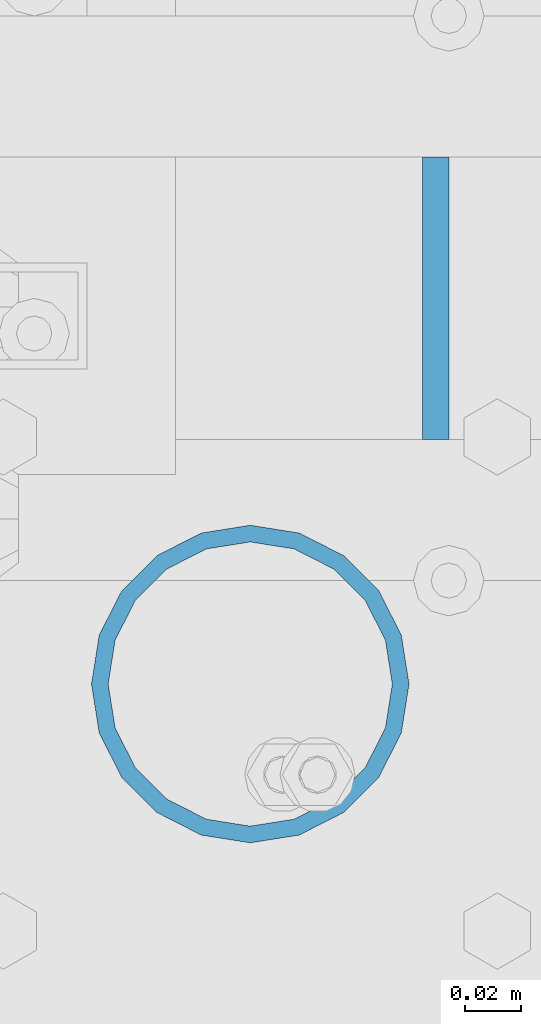
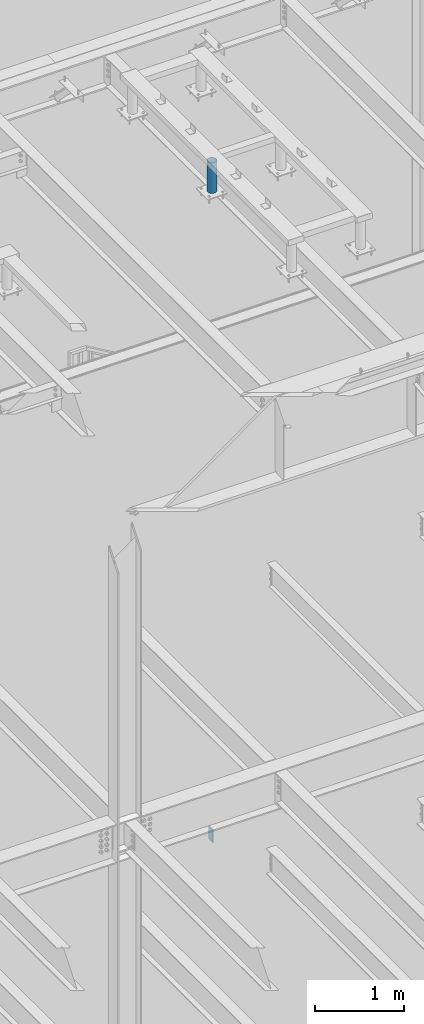
# One storey, part 563 of 1179: 2 columns, 2 elements without a shape of their own.
"""IFC2X3 building model written with IfcOpenShell, lengths in millimetres."""

import ifcopenshell
import ifcopenshell.guid

model = None  # the IFC model being written
_history = None  # IfcOwnerHistory: only IFC2X3 demands one
_inside = {}  # id of a spatial element -> (the spatial element, [elements in it])
_under = {}  # id of a project, library or spatial element -> (it, [spatial elements below it])
_declared = {}  # id of a project -> (the project, [libraries it declares])
_typed = {}  # id of a type object -> (the type object, [elements of that type])
_made_of = {}  # id of a material, layer set ... -> (it, [elements and type objects made of it])


def new_model(schema):
    """Start an empty IFC model of exactly this schema.

    Asked for "IFC4X3", IfcOpenShell would pick the latest addendum, in which some entities
    have other attributes; the version numbers below select the first issue.
    IFC2X3 requires an IfcOwnerHistory on every rooted entity: one is made here for all.
    """
    global model, _history
    if schema == "IFC4X3":
        model = ifcopenshell.file(schema_version=(4, 3, 0, 0))
    else:
        model = ifcopenshell.file(schema=schema)
    _inside.clear()
    _under.clear()
    _declared.clear()
    _typed.clear()
    _made_of.clear()
    _history = None
    if model.schema == "IFC2X3":
        org = make("IfcOrganization", Name="unknown")
        user = make(
            "IfcPersonAndOrganization",
            ThePerson=make("IfcPerson", FamilyName="unknown"),
            TheOrganization=org,
        )
        app = make(
            "IfcApplication",
            ApplicationDeveloper=org,
            Version="unknown",
            ApplicationFullName="unknown",
            ApplicationIdentifier="unknown",
        )
        _history = make(
            "IfcOwnerHistory",
            OwningUser=user,
            OwningApplication=app,
            ChangeAction="ADDED",
            CreationDate=0,
        )
    return model


def make(cls, **values):
    """One entity of the class cls with the attributes given. An attribute that is None is left unset."""
    return model.create_entity(
        cls, **{name: value for name, value in values.items() if value is not None}
    )


def rooted(cls, **values):
    """An entity with a GlobalId (a new one), such as an element, a storey or a relation."""
    return make(cls, GlobalId=ifcopenshell.guid.new(), OwnerHistory=_history, **values)


def si_unit(unit_type, name, prefix=None):
    """IfcSIUnit, for example si_unit("LENGTHUNIT", "METRE", prefix="MILLI")."""
    return make("IfcSIUnit", UnitType=unit_type, Prefix=prefix, Name=name)


def assignment(units):
    """IfcUnitAssignment: the units of a project."""
    return None if units is None else make("IfcUnitAssignment", Units=units)


def point(xyz):
    """IfcCartesianPoint."""
    return None if xyz is None else make("IfcCartesianPoint", Coordinates=xyz)


def direction(xyz):
    """IfcDirection."""
    return None if xyz is None else make("IfcDirection", DirectionRatios=xyz)


def frame(location, z_axis=None, x_axis=None):
    """IfcAxis2Placement3D, a coordinate frame: its origin and axes. An axis left out is left unset."""
    return make(
        "IfcAxis2Placement3D",
        Location=point(location),
        Axis=direction(z_axis),
        RefDirection=direction(x_axis),
    )


def origin_with_axes():
    """The frame at (0, 0, 0) with the z axis (0, 0, 1) and the x axis (1, 0, 0) written out."""
    return frame((0.0, 0.0, 0.0), z_axis=(0.0, 0.0, 1.0), x_axis=(1.0, 0.0, 0.0))


def place(relative_to, where):
    """IfcLocalPlacement: puts the frame where relative to a parent placement (None: the world)."""
    return make(
        "IfcLocalPlacement", PlacementRelTo=relative_to, RelativePlacement=where
    )


def context(
    kind, dimensions, precision=None, world=None, true_north=None, identifier=None
):
    """IfcGeometricRepresentationContext, for example the 3D "Model" context."""
    return make(
        "IfcGeometricRepresentationContext",
        ContextIdentifier=identifier,
        ContextType=kind,
        CoordinateSpaceDimension=dimensions,
        Precision=precision,
        WorldCoordinateSystem=world,
        TrueNorth=true_north,
    )


def subcontext(parent, identifier, kind, view, scale=None):
    """IfcGeometricRepresentationSubContext, for example "Body" below "Model"."""
    return make(
        "IfcGeometricRepresentationSubContext",
        ContextIdentifier=identifier,
        ContextType=kind,
        ParentContext=parent,
        TargetScale=scale,
        TargetView=view,
    )


def project(units=None, contexts=None):
    """IfcProject with its units and contexts."""
    return rooted(
        "IfcProject",
        Name="project",
        RepresentationContexts=contexts,
        UnitsInContext=assignment(units),
    )


def spatial(cls, under=None, at=None, **own):
    """A site, building, storey or space (cls), placed at a placement, below another one or the project."""
    s = rooted(cls, ObjectPlacement=at, **own)
    if under is not None:
        _under.setdefault(under.id(), (under, []))[1].append(s)
    return s


def faces_of(points, faces, orient=None, outer=None):
    """IfcFace entities. A face is a list of loops; a loop is a list of indices into points, from 0.

    orient and outer hold one flag for each loop. By default every Orientation is true, the
    first loop of a face is its IfcFaceOuterBound and the others are IfcFaceBound.
    """
    made = []
    for i, loops in enumerate(faces):
        bounds = []
        for j, loop in enumerate(loops):
            is_outer = j == 0 if outer is None else outer[i][j]
            bounds.append(
                make(
                    "IfcFaceOuterBound" if is_outer else "IfcFaceBound",
                    Bound=make("IfcPolyLoop", Polygon=[points[k] for k in loop]),
                    Orientation=True if orient is None else orient[i][j],
                )
            )
        made.append(make("IfcFace", Bounds=bounds))
    return made


def faceted_brep(points, faces, orient=None, outer=None, voids=None):
    """IfcFacetedBrep: a solid bounded by flat faces; with voids (closed shells), ...WithVoids."""
    shared = [point(p) for p in points]
    hull = make("IfcClosedShell", CfsFaces=faces_of(shared, faces, orient, outer))
    if voids is None:
        return make("IfcFacetedBrep", Outer=hull)
    return make(
        "IfcFacetedBrepWithVoids",
        Outer=hull,
        Voids=[
            make(cls, CfsFaces=faces_of(shared, fs, o, b)) for cls, fs, o, b in voids
        ],
    )


def shape(context_of_items, identifier, shape_type, items):
    """IfcShapeRepresentation: the items that make up one representation, for example the "Body"."""
    return make(
        "IfcShapeRepresentation",
        ContextOfItems=context_of_items,
        RepresentationIdentifier=identifier,
        RepresentationType=shape_type,
        Items=items,
    )


def material(Name=None, Category=None):
    """IfcMaterial."""
    return make("IfcMaterial", Name=Name, Category=Category)


def made_of(thing, what):
    """Note that an element or type object is made of a material, layer set ...; save() writes the relation."""
    if what is not None:
        _made_of.setdefault(what.id(), (what, []))[1].append(thing)
    return thing


def type_object(cls, material=None, **own):
    """A type object (cls), such as IfcWallType, which elements share."""
    return made_of(rooted(cls, **own), material)


def element(
    cls,
    number,
    at=None,
    inside=None,
    cuts=None,
    type_object=None,
    material=None,
    context=None,
    identifier="Body",
    shape_type=None,
    held_by="IfcProductDefinitionShape",
    body=None,
    shapes=None,
    **own,
):
    """One element of the class cls, such as IfcWall. Its Tag is "e" and its number.

    at: its placement. inside: the storey or other place that contains it. cuts: it is an
    opening in that element (IfcRelVoidsElement). A single representation is given by context,
    identifier, shape_type and body (its items); several are given by shapes. held_by: the class
    of the entity that holds the representations. save() writes the other relations.
    """
    e = rooted(cls, Tag="e%d" % number, ObjectPlacement=at, **own)
    if body is not None:
        shapes = [shape(context, identifier, shape_type, body)]
    if shapes is not None:
        e.Representation = make(held_by, Representations=shapes)
    if inside is not None:
        _inside.setdefault(inside.id(), (inside, []))[1].append(e)
    if cuts is not None:
        rooted(
            "IfcRelVoidsElement", RelatingBuildingElement=cuts, RelatedOpeningElement=e
        )
    if type_object is not None:
        _typed.setdefault(type_object.id(), (type_object, []))[1].append(e)
    return made_of(e, material)


def aggregate(whole, parts):
    """IfcRelAggregates: a whole, such as a stair, and the parts it consists of."""
    return rooted("IfcRelAggregates", RelatingObject=whole, RelatedObjects=parts)


def save(model, path):
    """Write the relations noted so far, then the file.

    IfcRelAggregates (storeys below a building ...), IfcRelContainedInSpatialStructure (elements
    in a storey), IfcRelDefinesByType, IfcRelAssociatesMaterial and IfcRelDeclares: one each for
    every whole, place, type object, material and project.
    """
    for whole, parts in _under.values():
        aggregate(whole, parts)
    for where, things in _inside.values():
        rooted(
            "IfcRelContainedInSpatialStructure",
            RelatedElements=things,
            RelatingStructure=where,
        )
    for kind, things in _typed.values():
        rooted("IfcRelDefinesByType", RelatedObjects=things, RelatingType=kind)
    for what, things in _made_of.values():
        rooted("IfcRelAssociatesMaterial", RelatedObjects=things, RelatingMaterial=what)
    for by, libraries in _declared.values():
        rooted("IfcRelDeclares", RelatingContext=by, RelatedDefinitions=libraries)
    model.write(path)


model = new_model("IFC2X3")

# Units and contexts
model_context = context("Model", 3, precision=1e-05, world=origin_with_axes())
body_context = subcontext(model_context, "Body", "Model", "MODEL_VIEW")
ifc_project = project(units=[si_unit("LENGTHUNIT", "METRE", prefix="MILLI"), si_unit("AREAUNIT", "SQUARE_METRE"), si_unit("VOLUMEUNIT", "CUBIC_METRE"), si_unit("MASSUNIT", "GRAM", prefix="KILO"), si_unit("TIMEUNIT", "SECOND"), si_unit("PLANEANGLEUNIT", "RADIAN"), si_unit("SOLIDANGLEUNIT", "STERADIAN"), si_unit("THERMODYNAMICTEMPERATUREUNIT", "DEGREE_CELSIUS"), si_unit("LUMINOUSINTENSITYUNIT", "LUMEN")], contexts=[model_context])

# Site, building, storey
site_placement = place(None, origin_with_axes())
site = spatial("IfcSite", under=ifc_project, at=site_placement, CompositionType="ELEMENT")
building_placement = place(site_placement, origin_with_axes())
building = spatial("IfcBuilding", under=site, at=building_placement, Name="Undefined", CompositionType="ELEMENT")
storey_placement = place(building_placement, origin_with_axes())
storey = spatial("IfcBuildingStorey", under=building, at=storey_placement, Name="Undefined", CompositionType="ELEMENT", Elevation=0.0)

# Assembly, column
assembly_1_placement = place(storey_placement, origin_with_axes())
assembly_1 = element("IfcElementAssembly", 1, at=assembly_1_placement, inside=storey, Name="STAIR", AssemblyPlace="NOTDEFINED", PredefinedType="RIGID_FRAME")
ifc_material_1 = material(Name="STEEL/A36")
column_type_1 = type_object("IfcColumnType", PredefinedType="NOTDEFINED")
column_1_placement = place(assembly_1_placement, frame((19750.087499823, 38157.1500000013, 4235.45000161793), z_axis=(0.0, -1.0, 0.0), x_axis=(0.0, 0.0, 1.0)))
column_1 = element("IfcColumn", 2, at=column_1_placement, type_object=column_type_1, material=ifc_material_1, Name="PLATE", context=body_context, shape_type="Brep", body=[
    faceted_brep([(0.0, 4.76249999999982, -50.7999999999993), (0.0, 4.76249999999982, 50.7999999999993), (177.572338034098, 4.76250000000073, 50.8000000000029), (177.572338034098, 4.76250000000073, -50.8000000000029), (0.0, -4.76249999999982, 50.7999999999993), (177.572338034098, -4.76250000000073, 50.8000000000029), (0.0, -4.76249999999982, -50.7999999999993), (177.572338034098, -4.76250000000073, -50.8000000000029)], [[[0, 1, 2, 3]], [[1, 4, 5, 2]], [[4, 6, 7, 5]], [[6, 0, 3, 7]], [[5, 7, 3, 2]], [[6, 4, 1, 0]]]),
])
aggregate(assembly_1, [column_1])

assembly_2_placement = place(storey_placement, origin_with_axes())
assembly_2 = element("IfcElementAssembly", 3, at=assembly_2_placement, inside=storey, Name="FRAME", AssemblyPlace="NOTDEFINED", PredefinedType="RIGID_FRAME")
ifc_material_2 = material()
column_type_2 = type_object("IfcColumnType", Name="PIPE4SCH40", PredefinedType="NOTDEFINED")
column_2_placement = place(assembly_2_placement, frame((19683.4125, 38018.3225542222, 13265.15), z_axis=(0.0, 1.0, 0.0), x_axis=(0.0, 0.0, 1.0)))
column_2 = element("IfcColumn", 4, at=column_2_placement, type_object=column_type_2, material=ifc_material_2, Name="COLUMN", ObjectType="PIPE4SCH40", context=body_context, shape_type="Brep", body=[
    faceted_brep([(0.0, -51.1301999999996, 0.0), (0.0, -48.6277098894752, 15.8001007257917), (419.099999999999, -48.6277098894752, 15.8001007257917), (419.099999999999, -51.1301999999996, 0.0), (0.0, -41.3652007257915, 30.0535775067619), (419.099999999999, -41.3652007257915, 30.0535775067619), (0.0, -30.0535775067656, 41.3652007257915), (419.099999999999, -30.0535775067656, 41.3652007257915), (0.0, -15.8001007257917, 48.6277098894716), (419.099999999999, -15.8001007257917, 48.6277098894716), (0.0, 0.0, 51.1301999999996), (419.099999999999, 0.0, 51.1301999999996), (0.0, 15.8001007257917, 48.6277098894716), (419.099999999999, 15.8001007257917, 48.6277098894716), (0.0, 30.0535775067656, 41.3652007257915), (419.099999999999, 30.0535775067656, 41.3652007257915), (0.0, 41.3652007257915, 30.0535775067619), (419.099999999999, 41.3652007257915, 30.0535775067619), (0.0, 48.6277098894752, 15.8001007257917), (419.099999999999, 48.6277098894752, 15.8001007257917), (0.0, 51.1301999999996, 0.0), (419.099999999999, 51.1301999999996, 0.0), (0.0, 48.6277098894752, -15.8001007257917), (419.099999999999, 48.6277098894752, -15.8001007257917), (0.0, 41.3652007257915, -30.0535775067619), (419.099999999999, 41.3652007257915, -30.0535775067619), (0.0, 30.0535775067656, -41.3652007257915), (419.099999999999, 30.0535775067656, -41.3652007257915), (0.0, 15.8001007257917, -48.6277098894716), (419.099999999999, 15.8001007257917, -48.6277098894716), (0.0, 0.0, -51.1301999999996), (419.099999999999, 0.0, -51.1301999999996), (0.0, -15.8001007257917, -48.6277098894716), (419.099999999999, -15.8001007257917, -48.6277098894716), (0.0, -30.0535775067656, -41.3652007257915), (419.099999999999, -30.0535775067656, -41.3652007257915), (0.0, -41.3652007257915, -30.0535775067619), (419.099999999999, -41.3652007257915, -30.0535775067619), (0.0, -48.6277098894752, -15.8001007257917), (419.099999999999, -48.6277098894752, -15.8001007257917), (0.0, -57.1500000000015, 0.0), (0.0, -54.3528799062697, -17.6603212285263), (419.099999999999, -54.3528799062697, -17.6603212285263), (419.099999999999, -57.1500000000015, 0.0), (0.0, -46.235321228527, -33.5919271685125), (419.099999999999, -46.235321228527, -33.5919271685125), (0.0, -33.5919271685161, -46.2353212285307), (419.099999999999, -33.5919271685161, -46.2353212285307), (0.0, -17.6603212285299, -54.3528799062697), (419.099999999999, -17.6603212285299, -54.3528799062697), (0.0, 0.0, -57.1500000000015), (419.099999999999, 0.0, -57.1500000000015), (0.0, 17.6603212285299, -54.3528799062697), (419.099999999999, 17.6603212285299, -54.3528799062697), (0.0, 33.5919271685161, -46.2353212285307), (419.099999999999, 33.5919271685161, -46.2353212285307), (0.0, 46.235321228527, -33.5919271685125), (419.099999999999, 46.235321228527, -33.5919271685125), (0.0, 54.3528799062697, -17.6603212285263), (419.099999999999, 54.3528799062697, -17.6603212285263), (0.0, 57.1500000000015, 0.0), (419.099999999999, 57.1500000000015, 0.0), (0.0, 54.3528799062697, 17.6603212285263), (419.099999999999, 54.3528799062697, 17.6603212285263), (0.0, 46.235321228527, 33.5919271685125), (419.099999999999, 46.235321228527, 33.5919271685125), (0.0, 33.5919271685161, 46.2353212285307), (419.099999999999, 33.5919271685161, 46.2353212285307), (0.0, 17.6603212285299, 54.3528799062697), (419.099999999999, 17.6603212285299, 54.3528799062697), (0.0, 0.0, 57.1500000000015), (419.099999999999, 0.0, 57.1500000000015), (0.0, -17.6603212285299, 54.3528799062697), (419.099999999999, -17.6603212285299, 54.3528799062697), (0.0, -33.5919271685161, 46.2353212285307), (419.099999999999, -33.5919271685161, 46.2353212285307), (0.0, -46.235321228527, 33.5919271685125), (419.099999999999, -46.235321228527, 33.5919271685125), (0.0, -54.3528799062697, 17.6603212285263), (419.099999999999, -54.3528799062697, 17.6603212285263)], [[[0, 1, 2, 3]], [[1, 4, 5, 2]], [[4, 6, 7, 5]], [[6, 8, 9, 7]], [[8, 10, 11, 9]], [[10, 12, 13, 11]], [[12, 14, 15, 13]], [[14, 16, 17, 15]], [[16, 18, 19, 17]], [[18, 20, 21, 19]], [[20, 22, 23, 21]], [[22, 24, 25, 23]], [[24, 26, 27, 25]], [[26, 28, 29, 27]], [[28, 30, 31, 29]], [[30, 32, 33, 31]], [[32, 34, 35, 33]], [[34, 36, 37, 35]], [[36, 38, 39, 37]], [[38, 0, 3, 39]], [[40, 41, 42, 43]], [[41, 44, 45, 42]], [[44, 46, 47, 45]], [[46, 48, 49, 47]], [[48, 50, 51, 49]], [[50, 52, 53, 51]], [[52, 54, 55, 53]], [[54, 56, 57, 55]], [[56, 58, 59, 57]], [[58, 60, 61, 59]], [[60, 62, 63, 61]], [[62, 64, 65, 63]], [[64, 66, 67, 65]], [[66, 68, 69, 67]], [[68, 70, 71, 69]], [[70, 72, 73, 71]], [[72, 74, 75, 73]], [[74, 76, 77, 75]], [[76, 78, 79, 77]], [[78, 40, 43, 79]], [[45, 47, 49, 51, 53, 55, 57, 59, 61, 63, 65, 67, 69, 71, 73, 75, 77, 79, 43, 42], [5, 7, 9, 11, 13, 15, 17, 19, 21, 23, 25, 27, 29, 31, 33, 35, 37, 39, 3, 2]], [[78, 76, 74, 72, 70, 68, 66, 64, 62, 60, 58, 56, 54, 52, 50, 48, 46, 44, 41, 40], [38, 36, 34, 32, 30, 28, 26, 24, 22, 20, 18, 16, 14, 12, 10, 8, 6, 4, 1, 0]]]),
])
aggregate(assembly_2, [column_2])

save(model, "model.ifc")
